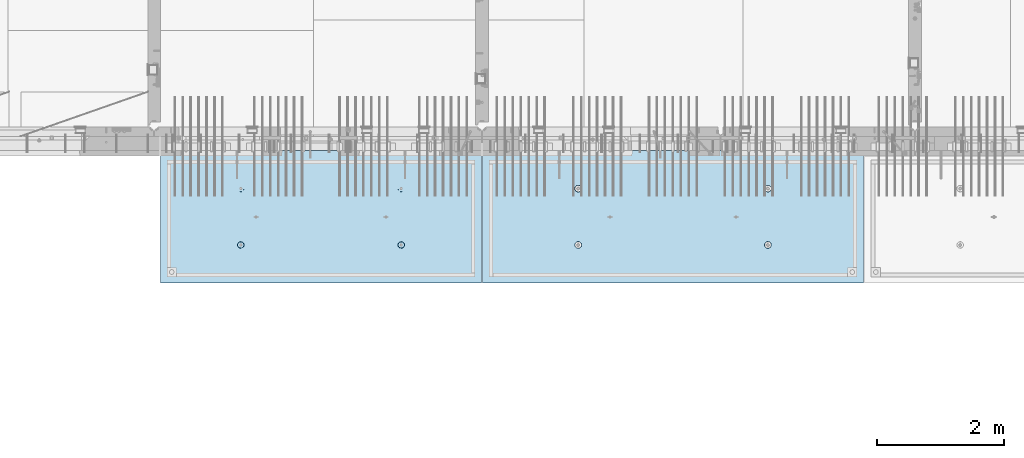
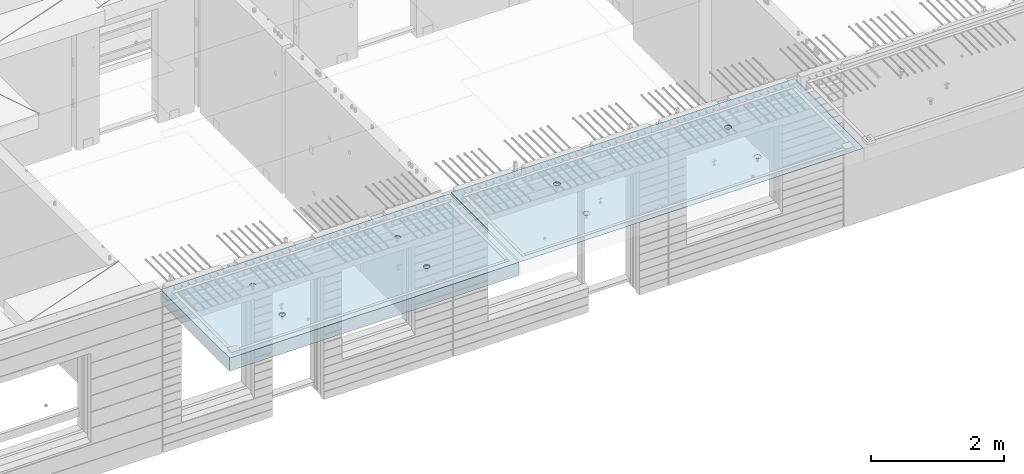
# One storey, part 195 of 341: 2 slabs, 2 elements without a shape of their own.
"""IFC2X3 building model written with IfcOpenShell, lengths in millimetres."""

import ifcopenshell
import ifcopenshell.guid

model = None  # the IFC model being written
_history = None  # IfcOwnerHistory: only IFC2X3 demands one
_inside = {}  # id of a spatial element -> (the spatial element, [elements in it])
_under = {}  # id of a project, library or spatial element -> (it, [spatial elements below it])
_declared = {}  # id of a project -> (the project, [libraries it declares])
_typed = {}  # id of a type object -> (the type object, [elements of that type])
_made_of = {}  # id of a material, layer set ... -> (it, [elements and type objects made of it])


def new_model(schema):
    """Start an empty IFC model of exactly this schema.

    Asked for "IFC4X3", IfcOpenShell would pick the latest addendum, in which some entities
    have other attributes; the version numbers below select the first issue.
    IFC2X3 requires an IfcOwnerHistory on every rooted entity: one is made here for all.
    """
    global model, _history
    if schema == "IFC4X3":
        model = ifcopenshell.file(schema_version=(4, 3, 0, 0))
    else:
        model = ifcopenshell.file(schema=schema)
    _inside.clear()
    _under.clear()
    _declared.clear()
    _typed.clear()
    _made_of.clear()
    _history = None
    if model.schema == "IFC2X3":
        org = make("IfcOrganization", Name="unknown")
        user = make(
            "IfcPersonAndOrganization",
            ThePerson=make("IfcPerson", FamilyName="unknown"),
            TheOrganization=org,
        )
        app = make(
            "IfcApplication",
            ApplicationDeveloper=org,
            Version="unknown",
            ApplicationFullName="unknown",
            ApplicationIdentifier="unknown",
        )
        _history = make(
            "IfcOwnerHistory",
            OwningUser=user,
            OwningApplication=app,
            ChangeAction="ADDED",
            CreationDate=0,
        )
    return model


def make(cls, **values):
    """One entity of the class cls with the attributes given. An attribute that is None is left unset."""
    return model.create_entity(
        cls, **{name: value for name, value in values.items() if value is not None}
    )


def rooted(cls, **values):
    """An entity with a GlobalId (a new one), such as an element, a storey or a relation."""
    return make(cls, GlobalId=ifcopenshell.guid.new(), OwnerHistory=_history, **values)


def si_unit(unit_type, name, prefix=None):
    """IfcSIUnit, for example si_unit("LENGTHUNIT", "METRE", prefix="MILLI")."""
    return make("IfcSIUnit", UnitType=unit_type, Prefix=prefix, Name=name)


def assignment(units):
    """IfcUnitAssignment: the units of a project."""
    return None if units is None else make("IfcUnitAssignment", Units=units)


def point(xyz):
    """IfcCartesianPoint."""
    return None if xyz is None else make("IfcCartesianPoint", Coordinates=xyz)


def direction(xyz):
    """IfcDirection."""
    return None if xyz is None else make("IfcDirection", DirectionRatios=xyz)


def frame(location, z_axis=None, x_axis=None):
    """IfcAxis2Placement3D, a coordinate frame: its origin and axes. An axis left out is left unset."""
    return make(
        "IfcAxis2Placement3D",
        Location=point(location),
        Axis=direction(z_axis),
        RefDirection=direction(x_axis),
    )


def origin_with_axes():
    """The frame at (0, 0, 0) with the z axis (0, 0, 1) and the x axis (1, 0, 0) written out."""
    return frame((0.0, 0.0, 0.0), z_axis=(0.0, 0.0, 1.0), x_axis=(1.0, 0.0, 0.0))


def place(relative_to, where):
    """IfcLocalPlacement: puts the frame where relative to a parent placement (None: the world)."""
    return make(
        "IfcLocalPlacement", PlacementRelTo=relative_to, RelativePlacement=where
    )


def context(
    kind, dimensions, precision=None, world=None, true_north=None, identifier=None
):
    """IfcGeometricRepresentationContext, for example the 3D "Model" context."""
    return make(
        "IfcGeometricRepresentationContext",
        ContextIdentifier=identifier,
        ContextType=kind,
        CoordinateSpaceDimension=dimensions,
        Precision=precision,
        WorldCoordinateSystem=world,
        TrueNorth=true_north,
    )


def subcontext(parent, identifier, kind, view, scale=None):
    """IfcGeometricRepresentationSubContext, for example "Body" below "Model"."""
    return make(
        "IfcGeometricRepresentationSubContext",
        ContextIdentifier=identifier,
        ContextType=kind,
        ParentContext=parent,
        TargetScale=scale,
        TargetView=view,
    )


def project(units=None, contexts=None):
    """IfcProject with its units and contexts."""
    return rooted(
        "IfcProject",
        Name="project",
        RepresentationContexts=contexts,
        UnitsInContext=assignment(units),
    )


def spatial(cls, under=None, at=None, **own):
    """A site, building, storey or space (cls), placed at a placement, below another one or the project."""
    s = rooted(cls, ObjectPlacement=at, **own)
    if under is not None:
        _under.setdefault(under.id(), (under, []))[1].append(s)
    return s


def faces_of(points, faces, orient=None, outer=None):
    """IfcFace entities. A face is a list of loops; a loop is a list of indices into points, from 0.

    orient and outer hold one flag for each loop. By default every Orientation is true, the
    first loop of a face is its IfcFaceOuterBound and the others are IfcFaceBound.
    """
    made = []
    for i, loops in enumerate(faces):
        bounds = []
        for j, loop in enumerate(loops):
            is_outer = j == 0 if outer is None else outer[i][j]
            bounds.append(
                make(
                    "IfcFaceOuterBound" if is_outer else "IfcFaceBound",
                    Bound=make("IfcPolyLoop", Polygon=[points[k] for k in loop]),
                    Orientation=True if orient is None else orient[i][j],
                )
            )
        made.append(make("IfcFace", Bounds=bounds))
    return made


def faceted_brep(points, faces, orient=None, outer=None, voids=None):
    """IfcFacetedBrep: a solid bounded by flat faces; with voids (closed shells), ...WithVoids."""
    shared = [point(p) for p in points]
    hull = make("IfcClosedShell", CfsFaces=faces_of(shared, faces, orient, outer))
    if voids is None:
        return make("IfcFacetedBrep", Outer=hull)
    return make(
        "IfcFacetedBrepWithVoids",
        Outer=hull,
        Voids=[
            make(cls, CfsFaces=faces_of(shared, fs, o, b)) for cls, fs, o, b in voids
        ],
    )


def shape(context_of_items, identifier, shape_type, items):
    """IfcShapeRepresentation: the items that make up one representation, for example the "Body"."""
    return make(
        "IfcShapeRepresentation",
        ContextOfItems=context_of_items,
        RepresentationIdentifier=identifier,
        RepresentationType=shape_type,
        Items=items,
    )


def material(Name=None, Category=None):
    """IfcMaterial."""
    return make("IfcMaterial", Name=Name, Category=Category)


def made_of(thing, what):
    """Note that an element or type object is made of a material, layer set ...; save() writes the relation."""
    if what is not None:
        _made_of.setdefault(what.id(), (what, []))[1].append(thing)
    return thing


def type_object(cls, material=None, **own):
    """A type object (cls), such as IfcWallType, which elements share."""
    return made_of(rooted(cls, **own), material)


def element(
    cls,
    number,
    at=None,
    inside=None,
    cuts=None,
    type_object=None,
    material=None,
    context=None,
    identifier="Body",
    shape_type=None,
    held_by="IfcProductDefinitionShape",
    body=None,
    shapes=None,
    **own,
):
    """One element of the class cls, such as IfcWall. Its Tag is "e" and its number.

    at: its placement. inside: the storey or other place that contains it. cuts: it is an
    opening in that element (IfcRelVoidsElement). A single representation is given by context,
    identifier, shape_type and body (its items); several are given by shapes. held_by: the class
    of the entity that holds the representations. save() writes the other relations.
    """
    e = rooted(cls, Tag="e%d" % number, ObjectPlacement=at, **own)
    if body is not None:
        shapes = [shape(context, identifier, shape_type, body)]
    if shapes is not None:
        e.Representation = make(held_by, Representations=shapes)
    if inside is not None:
        _inside.setdefault(inside.id(), (inside, []))[1].append(e)
    if cuts is not None:
        rooted(
            "IfcRelVoidsElement", RelatingBuildingElement=cuts, RelatedOpeningElement=e
        )
    if type_object is not None:
        _typed.setdefault(type_object.id(), (type_object, []))[1].append(e)
    return made_of(e, material)


def aggregate(whole, parts):
    """IfcRelAggregates: a whole, such as a stair, and the parts it consists of."""
    return rooted("IfcRelAggregates", RelatingObject=whole, RelatedObjects=parts)


def save(model, path):
    """Write the relations noted so far, then the file.

    IfcRelAggregates (storeys below a building ...), IfcRelContainedInSpatialStructure (elements
    in a storey), IfcRelDefinesByType, IfcRelAssociatesMaterial and IfcRelDeclares: one each for
    every whole, place, type object, material and project.
    """
    for whole, parts in _under.values():
        aggregate(whole, parts)
    for where, things in _inside.values():
        rooted(
            "IfcRelContainedInSpatialStructure",
            RelatedElements=things,
            RelatingStructure=where,
        )
    for kind, things in _typed.values():
        rooted("IfcRelDefinesByType", RelatedObjects=things, RelatingType=kind)
    for what, things in _made_of.values():
        rooted("IfcRelAssociatesMaterial", RelatedObjects=things, RelatingMaterial=what)
    for by, libraries in _declared.values():
        rooted("IfcRelDeclares", RelatingContext=by, RelatedDefinitions=libraries)
    model.write(path)


model = new_model("IFC2X3")

# Units and contexts
model_context = context("Model", 3, precision=1e-05, world=origin_with_axes())
body_context = subcontext(model_context, "Body", "Model", "MODEL_VIEW")
ifc_project = project(units=[si_unit("LENGTHUNIT", "METRE", prefix="MILLI"), si_unit("AREAUNIT", "SQUARE_METRE"), si_unit("VOLUMEUNIT", "CUBIC_METRE"), si_unit("MASSUNIT", "GRAM", prefix="KILO"), si_unit("TIMEUNIT", "SECOND"), si_unit("PLANEANGLEUNIT", "RADIAN"), si_unit("SOLIDANGLEUNIT", "STERADIAN"), si_unit("THERMODYNAMICTEMPERATUREUNIT", "DEGREE_CELSIUS"), si_unit("LUMINOUSINTENSITYUNIT", "LUMEN")], contexts=[model_context])

# Site, building, storey
site_placement = place(None, origin_with_axes())
site = spatial("IfcSite", under=ifc_project, at=site_placement, CompositionType="ELEMENT")
building_placement = place(site_placement, origin_with_axes())
building = spatial("IfcBuilding", under=site, at=building_placement, CompositionType="ELEMENT")
storey_placement = place(building_placement, origin_with_axes())
storey = spatial("IfcBuildingStorey", under=building, at=storey_placement, Name="5", CompositionType="ELEMENT", Elevation=0.0)

# Assembly, slab
assembly_1_placement = place(storey_placement, origin_with_axes())
assembly_1 = element("IfcElementAssembly", 1, at=assembly_1_placement, inside=storey, AssemblyPlace="NOTDEFINED", PredefinedType="REINFORCEMENT_UNIT")
ifc_material = material(Name="CONCRETE/C35/45")
slab_type_1 = type_object("IfcSlabType", PredefinedType="NOTDEFINED")
slab_1_placement = place(assembly_1_placement, frame((27799.9998568133, 7629.99655735226, 96720.0), z_axis=(-1.11800000013248e-06, -0.999999999999375, 0.0), x_axis=(-0.999999999999093, 1.34699999998405e-06, 0.0)))
slab_1 = element("IfcSlab", 2, at=slab_1_placement, type_object=slab_type_1, material=ifc_material, PredefinedType="FLOOR", context=body_context, shape_type="Brep", body=[
    faceted_brep([(4430.38332613536, -4.08995228011918, 616.123557002266), (4431.90609271965, 10.0, 615.628782084005), (4439.08875686405, 10.0, 629.725594302773), (4437.8062304225, -3.95053914321761, 630.657402050439), (4450.27603094506, 10.0, 640.912894136913), (4449.35160622641, -3.83996043598745, 642.185252526786), (4464.3728266293, 10.0, 648.095590732159), (4463.88931892896, -3.76899254079035, 649.583668593681), (4479.99925133704, 10.0, 650.570591700976), (4479.99924953932, -3.74454363348195, 652.132471659324), (4495.6256817422, 10.0, 648.095626704194), (4496.1091860045, -3.76899218543258, 649.583705640341), (4509.72249396096, 10.0, 640.912962559792), (4510.64691570547, -3.83995975981816, 642.185323015524), (4520.9097937951, 10.0, 629.725688478787), (4522.19231800603, -3.95053821212787, 630.657499116635), (4528.09249039035, 10.0, 615.628892794549), (4529.6152557173, -4.08995118488383, 616.123671179757), (4530.56749135917, 10.0, 600.002468086805), (4532.18619485158, -4.24459073322942, 600.002469949934), (4528.09252636238, 10.0, 584.37603768165), (4529.64872932557, -4.39933455047139, 583.870398667863), (4520.90986221798, 10.0, 570.279225462882), (4522.24649000407, -4.53902051890327, 569.308110882728), (4509.72258813697, 10.0, 559.091925628744), (4510.70111430095, -4.6499364652409, 557.745103167879), (4495.62579245274, 10.0, 551.909229033497), (4496.142736776, -4.72117719323433, 550.318244231095), (4479.99936774499, 10.0, 549.43422806468), (4479.99936967367, -4.74573031402542, 547.758576892632), (4464.37293733984, 10.0, 551.909193061462), (4463.8559966665, -4.72117755009094, 550.318207030491), (4450.27612512107, 10.0, 559.091857205865), (4449.29760201216, -4.64993714379671, 557.745032430054), (4439.08882528693, 10.0, 570.279131286869), (4437.75219965053, -4.53902145239408, 569.308013567449), (4431.90612869169, 10.0, 584.375926971106), (4430.34992677396, -4.39933564719104, 583.87028433643), (4429.43112772287, 10.0, 600.002351678851), (4427.81242409951, -4.24459188559558, 600.002349815723), (0.0, 10.0, 0.0), (0.0, -10.0, 0.0), (0.000819232023786753, 10.0, 2085.00366210937), (5980.0, 10.0, -2.4019755073823e-09), (5980.0, -10.0, -2.4019755073823e-09), (5980.0009765625, 10.0, 2085.00366210937), (1450.3499233011, -4.39936856077111, 583.866853138679), (1451.90612877595, 10.0, 584.37249692914), (1449.43112780714, 10.0, 599.998921636884), (1447.81242044485, -4.24462478808709, 599.998919773752), (1457.75219670802, -4.53905437597132, 569.304581326389), (1459.0888253712, 10.0, 570.275701244902), (1469.29759989681, -4.64997007531929, 557.741599360567), (1470.27612520534, 10.0, 559.088427163899), (1483.85599559418, -4.7212104867067, 550.31477342891), (1484.3729374241, 10.0, 551.905763019495), (1499.99936975794, -4.74576325241651, 547.755143107666), (1499.99936782926, 10.0, 549.430798022713), (1516.14273801685, -4.72121012986463, 550.314810629518), (1515.62579253701, 10.0, 551.905798991532), (1530.70111658485, -4.64996939677803, 557.741670098397), (1529.72258822124, 10.0, 559.088495586778), (1542.24649311513, -4.53905344249506, 569.304678641675), (1540.90986230225, 10.0, 570.275795420916), (1549.64873296696, -4.39936746405147, 583.866967470121), (1548.09252644665, 10.0, 584.372607639683), (1552.18619867476, -4.24462363570638, 599.999039907971), (1550.56749144343, 10.0, 599.999038044839), (1549.61525935629, -4.08998407628678, 616.120242292795), (1548.09249047462, 10.0, 615.625462752582), (1542.19232111321, -3.95057109353365, 630.654071270945), (1540.90979387937, 10.0, 629.72225843682), (1530.64691798548, -3.83999263332225, 642.181895995745), (1529.72249404523, 10.0, 640.909532517825), (1516.10918724295, -3.76902505384351, 649.580279150618), (1515.62568182647, 10.0, 648.092196662228), (1499.99924962358, -3.7445765001321, 652.129045352205), (1499.9992514213, 10.0, 650.56716165901), (1483.88931785903, -3.76902540921583, 649.580242103954), (1484.37282671356, 10.0, 648.092160690191), (1469.35160411493, -3.83999330949155, 642.181825507), (1470.27603102933, 10.0, 640.909464094946), (1457.80622748385, -3.9505720246525, 630.653974204743), (1459.08875694832, 10.0, 629.722164260806), (1450.3833226649, -4.08998517153668, 616.120128115297), (1451.90609280392, 10.0, 615.625352042039), (1450.18528173966, 4.08930273250735, 1468.81238974452), (1450.82407776805, 10.0, 1469.01994796889), (1448.29345879993, 10.0, 1484.99752828805), (1447.63943102495, 4.24455558012414, 1484.99752753526), (1457.61190709188, 3.94915737991687, 1454.20221107617), (1458.16818327555, 10.0, 1454.60637035917), (1469.19529226424, 3.83787679090165, 1442.60118929624), (1469.60688310596, 10.0, 1443.16769686061), (1483.80158206606, 3.76640201332339, 1435.14993064656), (1484.02047762178, 10.0, 1435.82362453319), (1499.99806458492, 3.74176847410854, 1432.58187967207), (1499.99806376637, 10.0, 1433.29304234547), (1516.19454117951, 3.76640237134416, 1435.14996796955), (1515.97564408552, 10.0, 1435.82366131359), (1530.80081379559, 3.8378774716839, 1442.60126026678), (1530.38922169525, 10.0, 1443.16776682109), (1542.38417222175, 3.94915831647813, 1454.2023087116), (1541.82789519381, 10.0, 1454.6064666515), (1549.8107639085, 4.08930383282132, 1468.81250445209), (1549.17196752123, 10.0, 1469.02006116732), (1552.35657735256, 4.24455673628836, 1484.9976480647), (1551.70254970896, 10.0, 1484.99764731191), (1549.77718017658, 4.39970502781216, 1501.17188586406), (1549.17193074083, 10.0, 1500.97522763107), (1542.32982200517, 4.53957665037888, 1515.75352812725), (1541.82782523334, 10.0, 1515.38880524079), (1530.74643689407, 4.65051889081951, 1527.31927700612), (1530.38912540293, 10.0, 1526.82747873935), (1516.16088003051, 4.72171993891243, 1534.74199930817), (1515.9755308871, 10.0, 1534.17155106677), (1499.99794405534, 4.74624892331485, 1537.2991504223), (1499.99794474251, 10.0, 1536.70213325449), (1483.83501395426, 4.72171958237595, 1534.74196213963), (1484.02036442336, 10.0, 1534.17151428637), (1469.24947414505, 4.65051821242378, 1527.31920628548), (1469.60678681363, 10.0, 1526.82740877888), (1457.66611561777, 4.53957571620413, 1515.75343074172), (1458.16811331507, 10.0, 1515.38870894846), (1450.21879098044, 4.39970392896794, 1501.17177131094), (1450.82404098765, 10.0, 1500.97511443265), (4495.97553080284, 10.0, 1534.17498110874), (4496.16087879206, 4.72175280732336, 1534.74542579789), (4479.99794397108, 4.746281789965, 1537.30257672942), (4479.99794465824, 10.0, 1536.70556329646), (4510.38912531866, 10.0, 1526.83090878132), (4510.74643461406, 4.65055176430906, 1527.3227040259), (4521.82782514907, 10.0, 1515.39223528276), (4522.32981889799, 4.53960953179921, 1515.75695597294), (4529.17193065656, 10.0, 1500.97865767303), (4529.77717653759, 4.39973791921511, 1501.17531475103), (4531.70254962468, 10.0, 1485.00107735388), (4532.35657352936, 4.24458963877987, 1485.00107810666), (4529.17196743696, 10.0, 1469.02349120928), (4529.8107602671, 4.08933674640139, 1468.81593564983), (4521.82789510954, 10.0, 1454.60989669347), (4522.38416911069, 3.94919124005537, 1454.20574095265), (4510.38922161098, 10.0, 1443.17119686305), (4510.8008115117, 3.83791040322103, 1442.60469333626), (4495.97564400126, 10.0, 1435.82709135556), (4496.19453993865, 3.76643530797446, 1435.15340157113), (4479.99806368211, 10.0, 1433.29647238744), (4479.99806450065, 3.74180141248507, 1432.58531345704), (4464.02047753751, 10.0, 1435.82705457516), (4463.80158313838, 3.76643494995369, 1435.15336424814), (4449.60688302169, 10.0, 1443.17112690258), (4449.19529437959, 3.83790972242423, 1442.60462236572), (4438.16818319128, 10.0, 1454.60980040114), (4437.61191003439, 3.94919030349411, 1454.20564331723), (4430.82407768378, 10.0, 1469.02337801086), (4430.18528521251, 4.08933564607287, 1468.81582094227), (4437.66611855642, 4.53960859763902, 1515.75685858742), (4449.24947625653, 4.65055108592787, 1527.32263330526), (4463.83501502419, 4.72175245078688, 1534.74538862936), (4427.63943467959, 4.24458848261565, 1485.00095757723), (4430.2187944509, 4.39973682038544, 1501.17520019791), (4464.02036433909, 10.0, 1534.17494432834), (4449.60678672936, 10.0, 1526.83083882084), (4438.1681132308, 10.0, 1515.39213899043), (4430.82404090338, 10.0, 1500.97854447461), (4428.29345871566, 10.0, 1485.00095833002)], [[[0, 1, 2, 3]], [[3, 2, 4, 5]], [[5, 4, 6, 7]], [[7, 6, 8, 9]], [[10, 11, 9, 8]], [[12, 13, 11, 10]], [[14, 15, 13, 12]], [[16, 17, 15, 14]], [[18, 19, 17, 16]], [[20, 21, 19, 18]], [[22, 23, 21, 20]], [[24, 25, 23, 22]], [[26, 27, 25, 24]], [[27, 26, 28, 29]], [[29, 28, 30, 31]], [[31, 30, 32, 33]], [[33, 32, 34, 35]], [[35, 34, 36, 37]], [[37, 36, 38, 39]], [[39, 38, 1, 0]], [[40, 41, 42]], [[40, 43, 44, 41]], [[43, 45, 44]], [[46, 47, 48, 49]], [[50, 51, 47, 46]], [[52, 53, 51, 50]], [[54, 55, 53, 52]], [[56, 57, 55, 54]], [[58, 59, 57, 56]], [[59, 58, 60, 61]], [[61, 60, 62, 63]], [[63, 62, 64, 65]], [[65, 64, 66, 67]], [[67, 66, 68, 69]], [[69, 68, 70, 71]], [[71, 70, 72, 73]], [[73, 72, 74, 75]], [[75, 74, 76, 77]], [[78, 79, 77, 76]], [[80, 81, 79, 78]], [[82, 83, 81, 80]], [[84, 85, 83, 82]], [[49, 48, 85, 84]], [[86, 87, 88, 89]], [[90, 91, 87, 86]], [[92, 93, 91, 90]], [[94, 95, 93, 92]], [[96, 97, 95, 94]], [[98, 99, 97, 96]], [[100, 101, 99, 98]], [[101, 100, 102, 103]], [[103, 102, 104, 105]], [[105, 104, 106, 107]], [[107, 106, 108, 109]], [[109, 108, 110, 111]], [[111, 110, 112, 113]], [[113, 112, 114, 115]], [[115, 114, 116, 117]], [[117, 116, 118, 119]], [[120, 121, 119, 118]], [[122, 123, 121, 120]], [[124, 125, 123, 122]], [[89, 88, 125, 124]], [[126, 127, 128, 129]], [[130, 131, 127, 126]], [[132, 133, 131, 130]], [[134, 135, 133, 132]], [[136, 137, 135, 134]], [[138, 139, 137, 136]], [[140, 141, 139, 138]], [[142, 143, 141, 140]], [[143, 142, 144, 145]], [[145, 144, 146, 147]], [[147, 146, 148, 149]], [[149, 148, 150, 151]], [[151, 150, 152, 153]], [[153, 152, 154, 155]], [[41, 44, 45, 42], [3, 5, 7, 9, 11, 13, 15, 17, 19, 21, 23, 25, 27, 29, 31, 33, 35, 37, 39, 0], [156, 157, 158, 128, 127, 131, 133, 135, 137, 139, 141, 143, 145, 147, 149, 151, 153, 155, 159, 160], [122, 120, 118, 116, 114, 112, 110, 108, 106, 104, 102, 100, 98, 96, 94, 92, 90, 86, 89, 124], [82, 80, 78, 76, 74, 72, 70, 68, 66, 64, 62, 60, 58, 56, 54, 52, 50, 46, 49, 84]], [[129, 128, 158, 161]], [[157, 162, 161, 158]], [[156, 163, 162, 157]], [[160, 164, 163, 156]], [[159, 165, 164, 160]], [[155, 154, 165, 159]], [[43, 40, 42, 45], [34, 32, 30, 28, 26, 24, 22, 20, 18, 16, 14, 12, 10, 8, 6, 4, 2, 1, 38, 36], [152, 150, 148, 146, 144, 142, 140, 138, 136, 134, 132, 130, 126, 129, 161, 162, 163, 164, 165, 154], [91, 93, 95, 97, 99, 101, 103, 105, 107, 109, 111, 113, 115, 117, 119, 121, 123, 125, 88, 87], [51, 53, 55, 57, 59, 61, 63, 65, 67, 69, 71, 73, 75, 77, 79, 81, 83, 85, 48, 47]]]),
])
aggregate(assembly_1, [slab_1])

assembly_2_placement = place(storey_placement, origin_with_axes())
assembly_2 = element("IfcElementAssembly", 3, at=assembly_2_placement, inside=storey, AssemblyPlace="NOTDEFINED", PredefinedType="REINFORCEMENT_UNIT")
slab_type_2 = type_object("IfcSlabType", PredefinedType="NOTDEFINED")
slab_2_placement = place(assembly_2_placement, frame((21799.9998568133, 7629.99655735226, 96590.0), z_axis=(-1.11800000013248e-06, -0.999999999999375, 0.0), x_axis=(-0.999999999999093, 1.34699999998405e-06, 0.0)))
slab_2 = element("IfcSlab", 4, at=slab_2_placement, type_object=slab_type_2, material=ifc_material, PredefinedType="FLOOR", context=body_context, shape_type="Brep", body=[
    faceted_brep([(1275.44980856604, -115.0, 552.444777751491), (1289.3882117606, -115.0, 559.546772887367), (1300.44978375459, -115.0, 570.608375101608), (1307.55174081072, -115.0, 584.54679769877), (1309.9988938901, -115.0, 599.997650760343), (1307.551698599, -115.0, 615.448497136235), (1300.44970346313, -115.0, 629.3869003308), (1289.38810124889, -115.0, 640.448472324786), (1275.44967865172, -115.0, 647.550429380917), (1259.99882559015, -115.0, 649.997582460297), (1244.54797921425, -115.0, 647.550387169195), (1230.60957601969, -115.0, 640.44839203332), (1219.54800402571, -115.0, 629.386789819078), (1212.44604696957, -115.0, 615.448367221916), (1209.9988938902, -115.0, 599.997514160343), (1212.4460891813, -115.0, 584.546667784451), (1219.54808431717, -115.0, 570.608264589886), (1230.60968653141, -115.0, 559.546692595902), (1244.54810912857, -115.0, 552.444735539769), (1259.99896219015, -115.0, 549.99758246039), (1219.08841602657, -120.0, 570.274295068632), (1211.90571640051, -120.0, 584.371089208588), (1230.27571826597, -120.0, 559.087023392896), (1244.37253202901, -120.0, 551.904362279308), (1259.99896296629, -120.0, 549.429400642209), (1275.6253871419, -120.0, 551.904404970708), (1289.72218128186, -120.0, 559.087104596764), (1300.9094529576, -120.0, 570.274406836168), (1308.09211407118, -120.0, 584.371220599207), (1310.56707570828, -120.0, 599.99765153648), (1308.09207137979, -120.0, 615.624075712098), (1300.90937175373, -120.0, 629.720869852056), (1289.72206951433, -120.0, 640.90814152779), (1275.62525575129, -120.0, 648.090802641378), (1259.99882481401, -120.0, 650.565764278478), (1244.37240063839, -120.0, 648.090759949978), (1230.27560649844, -120.0, 640.908060323922), (1219.0883348227, -120.0, 629.72075808452), (1211.90567370912, -120.0, 615.623944321479), (1209.43071207202, -120.0, 599.997513384206), (0.000328360383718973, -120.0, 2085.00366210938), (5040.00048828125, -120.0, 2085.00366210938), (5040.00048828125, 120.0, 2085.00366210938), (0.000328360383718973, 120.0, 2085.00366210938), (5040.0, -120.0, -2.18278728425503e-09), (5040.0, 120.0, -2.18278728425503e-09), (-7.27595761418343e-12, -120.0, -9.09494701772928e-13), (-7.27595761418343e-12, 120.0, -9.09494701772928e-13), (1275.44859965604, -105.0, 1437.44477775066), (1289.38700285061, -105.0, 1444.54677288654), (1300.44857484459, -105.0, 1455.60837510078), (1307.55053190072, -105.0, 1469.54679769794), (1309.9976849801, -105.0, 1484.99765075952), (1307.550489689, -105.0, 1500.44849713541), (1300.44849455313, -105.0, 1514.38690032997), (1289.38689233888, -105.0, 1525.44847232396), (1275.44846974172, -105.0, 1532.55042938009), (1259.99761668015, -105.0, 1534.99758245947), (1244.54677030425, -105.0, 1532.55038716837), (1230.60836710969, -105.0, 1525.44839203249), (1219.5467951157, -105.0, 1514.38678981825), (1212.44483805958, -105.0, 1500.44836722109), (1209.99768498019, -105.0, 1484.99751415952), (1212.44488027129, -105.0, 1469.54666778362), (1219.54687540717, -105.0, 1455.60826458906), (1230.60847762142, -105.0, 1444.54669259508), (1244.54690021857, -105.0, 1437.44473553894), (1259.99775328015, -105.0, 1434.99758245956), (1210.82376192895, -120.0, 1469.01993205604), (1208.29313952565, -120.0, 1484.99751183111), (1218.16787053537, -120.0, 1454.60635602529), (1229.60657282509, -120.0, 1443.16768498606), (1244.02016891989, -120.0, 1435.82361575756), (1259.99775560856, -120.0, 1433.29303700502), (1275.97533538363, -120.0, 1435.82365940832), (1290.38891141437, -120.0, 1443.16776801474), (1301.82758245361, -120.0, 1454.60647030446), (1309.17165168211, -120.0, 1469.02006639925), (1311.70223043464, -120.0, 1484.99765308793), (1309.17160803135, -120.0, 1500.975232863), (1301.82749942493, -120.0, 1515.38880889374), (1290.3887971352, -120.0, 1526.82747993297), (1275.97520104041, -120.0, 1534.17154916147), (1259.99761435174, -120.0, 1536.70212791401), (1244.02003457667, -120.0, 1534.17150551072), (1229.60645854592, -120.0, 1526.8273969043), (1218.16778750669, -120.0, 1515.38869461457), (1210.82371827819, -120.0, 1500.97509851978), (3795.4485995714, -105.0, 1437.44822013263), (3809.38700276596, -105.0, 1444.55021526851), (3820.44857475995, -105.0, 1455.61181748275), (3827.55053181608, -105.0, 1469.55024007991), (3829.99768489545, -105.0, 1485.00109314148), (3827.55048960436, -105.0, 1500.45193951738), (3820.44849446848, -105.0, 1514.39034271194), (3809.38689225424, -105.0, 1525.45191470593), (3795.44846965708, -105.0, 1532.55387176206), (3779.9976165955, -105.0, 1535.00102484144), (3764.54677021961, -105.0, 1532.55382955034), (3750.60836702505, -105.0, 1525.45183441446), (3739.54679503106, -105.0, 1514.39023220022), (3732.44483797493, -105.0, 1500.45180960306), (3729.99768489555, -105.0, 1485.00095654148), (3732.44488018665, -105.0, 1469.55011016559), (3739.54687532252, -105.0, 1455.61170697103), (3750.60847753677, -105.0, 1444.55013497704), (3764.54690013393, -105.0, 1437.44817792091), (3779.9977531955, -105.0, 1435.00102484153), (3730.82376184431, -120.0, 1469.023374438), (3728.293139441, -120.0, 1485.00095421308), (3738.16787045072, -120.0, 1454.60979840726), (3749.60657274045, -120.0, 1443.17112736803), (3764.02016883524, -120.0, 1435.82705813953), (3779.99775552391, -120.0, 1433.29647938699), (3795.97533529898, -120.0, 1435.82710179029), (3810.38891132972, -120.0, 1443.1712103967), (3821.82758236896, -120.0, 1454.60991268643), (3829.17165159746, -120.0, 1469.02350878122), (3831.70223035, -120.0, 1485.00109546989), (3829.1716079467, -120.0, 1500.97867524497), (3821.82749934028, -120.0, 1515.39225127571), (3810.38879705056, -120.0, 1526.83092231494), (3795.97520095576, -120.0, 1534.17499154344), (3779.99761426709, -120.0, 1536.70557029598), (3764.02003449202, -120.0, 1534.17494789268), (3749.60645846128, -120.0, 1526.83083928627), (3738.16778742204, -120.0, 1515.39213699654), (3730.82371819355, -120.0, 1500.97854090175), (3795.4498084814, -115.0, 552.448220133458), (3809.38821167596, -115.0, 559.550215269334), (3820.44978366995, -115.0, 570.611817483575), (3827.55174072608, -115.0, 584.550240080738), (3829.99889380546, -115.0, 600.00109314231), (3827.55169851435, -115.0, 615.451939518203), (3820.44970337848, -115.0, 629.390342712767), (3809.38810116424, -115.0, 640.451914706753), (3795.44967856708, -115.0, 647.553871762884), (3779.9988255055, -115.0, 650.001024842264), (3764.54797912961, -115.0, 647.553829551163), (3750.60957593505, -115.0, 640.451834415288), (3739.54800394106, -115.0, 629.390232201046), (3732.44604688493, -115.0, 615.451809603883), (3729.99889380555, -115.0, 600.000956542311), (3732.44608909665, -115.0, 584.550110166418), (3739.54808423252, -115.0, 570.611706971854), (3750.60968644677, -115.0, 559.550134977869), (3764.54810904393, -115.0, 552.448177921737), (3779.9989621055, -115.0, 550.001024842357), (3731.90571631587, -120.0, 584.374531590555), (3729.43071198737, -120.0, 600.000955766174), (3739.08841594193, -120.0, 570.277737450599), (3750.27571818133, -120.0, 559.090465774863), (3764.37253194437, -120.0, 551.907804661275), (3779.99896288164, -120.0, 549.432843024176), (3795.62538705726, -120.0, 551.907847352675), (3809.72218119721, -120.0, 559.090546978732), (3820.90945287295, -120.0, 570.277849218135), (3828.09211398654, -120.0, 584.374662981175), (3830.56707562364, -120.0, 600.001093918447), (3828.09207129514, -120.0, 615.627518094066), (3820.90937166908, -120.0, 629.724312234023), (3809.72206942968, -120.0, 640.911583909758), (3795.62525566664, -120.0, 648.094245023345), (3779.99882472937, -120.0, 650.569206660445), (3764.37240055375, -120.0, 648.094202331945), (3750.27560641379, -120.0, 640.911502705889), (3739.08833473806, -120.0, 629.724200466487), (3731.90567362447, -120.0, 615.627386703446)], [[[0, 1, 2, 3, 4, 5, 6, 7, 8, 9, 10, 11, 12, 13, 14, 15, 16, 17, 18, 19]], [[20, 16, 15, 21]], [[22, 17, 16, 20]], [[23, 18, 17, 22]], [[24, 19, 18, 23]], [[25, 0, 19, 24]], [[26, 1, 0, 25]], [[27, 2, 1, 26]], [[28, 3, 2, 27]], [[29, 4, 3, 28]], [[30, 5, 4, 29]], [[31, 6, 5, 30]], [[32, 7, 6, 31]], [[33, 8, 7, 32]], [[34, 9, 8, 33]], [[35, 10, 9, 34]], [[36, 11, 10, 35]], [[37, 12, 11, 36]], [[38, 13, 12, 37]], [[39, 14, 13, 38]], [[21, 15, 14, 39]], [[40, 41, 42, 43]], [[41, 44, 45, 42]], [[44, 46, 47, 45]], [[42, 45, 47, 43]], [[46, 40, 43, 47]], [[48, 49, 50, 51, 52, 53, 54, 55, 56, 57, 58, 59, 60, 61, 62, 63, 64, 65, 66, 67]], [[68, 63, 62, 69]], [[70, 64, 63, 68]], [[71, 65, 64, 70]], [[72, 66, 65, 71]], [[73, 67, 66, 72]], [[74, 48, 67, 73]], [[75, 49, 48, 74]], [[76, 50, 49, 75]], [[77, 51, 50, 76]], [[78, 52, 51, 77]], [[79, 53, 52, 78]], [[80, 54, 53, 79]], [[81, 55, 54, 80]], [[82, 56, 55, 81]], [[83, 57, 56, 82]], [[84, 58, 57, 83]], [[85, 59, 58, 84]], [[86, 60, 59, 85]], [[87, 61, 60, 86]], [[69, 62, 61, 87]], [[88, 89, 90, 91, 92, 93, 94, 95, 96, 97, 98, 99, 100, 101, 102, 103, 104, 105, 106, 107]], [[108, 103, 102, 109]], [[110, 104, 103, 108]], [[111, 105, 104, 110]], [[112, 106, 105, 111]], [[113, 107, 106, 112]], [[114, 88, 107, 113]], [[115, 89, 88, 114]], [[116, 90, 89, 115]], [[117, 91, 90, 116]], [[118, 92, 91, 117]], [[119, 93, 92, 118]], [[120, 94, 93, 119]], [[121, 95, 94, 120]], [[122, 96, 95, 121]], [[123, 97, 96, 122]], [[124, 98, 97, 123]], [[125, 99, 98, 124]], [[126, 100, 99, 125]], [[127, 101, 100, 126]], [[109, 102, 101, 127]], [[128, 129, 130, 131, 132, 133, 134, 135, 136, 137, 138, 139, 140, 141, 142, 143, 144, 145, 146, 147]], [[148, 143, 142, 149]], [[150, 144, 143, 148]], [[151, 145, 144, 150]], [[152, 146, 145, 151]], [[153, 147, 146, 152]], [[154, 128, 147, 153]], [[155, 129, 128, 154]], [[156, 130, 129, 155]], [[157, 131, 130, 156]], [[158, 132, 131, 157]], [[159, 133, 132, 158]], [[160, 134, 133, 159]], [[161, 135, 134, 160]], [[162, 136, 135, 161]], [[163, 137, 136, 162]], [[164, 138, 137, 163]], [[165, 139, 138, 164]], [[166, 140, 139, 165]], [[167, 141, 140, 166]], [[149, 142, 141, 167]], [[44, 41, 40, 46], [37, 36, 35, 34, 33, 32, 31, 30, 29, 28, 27, 26, 25, 24, 23, 22, 20, 21, 39, 38], [166, 165, 164, 163, 162, 161, 160, 159, 158, 157, 156, 155, 154, 153, 152, 151, 150, 148, 149, 167], [126, 125, 124, 123, 122, 121, 120, 119, 118, 117, 116, 115, 114, 113, 112, 111, 110, 108, 109, 127], [86, 85, 84, 83, 82, 81, 80, 79, 78, 77, 76, 75, 74, 73, 72, 71, 70, 68, 69, 87]]]),
])
aggregate(assembly_2, [slab_2])

save(model, "model.ifc")
